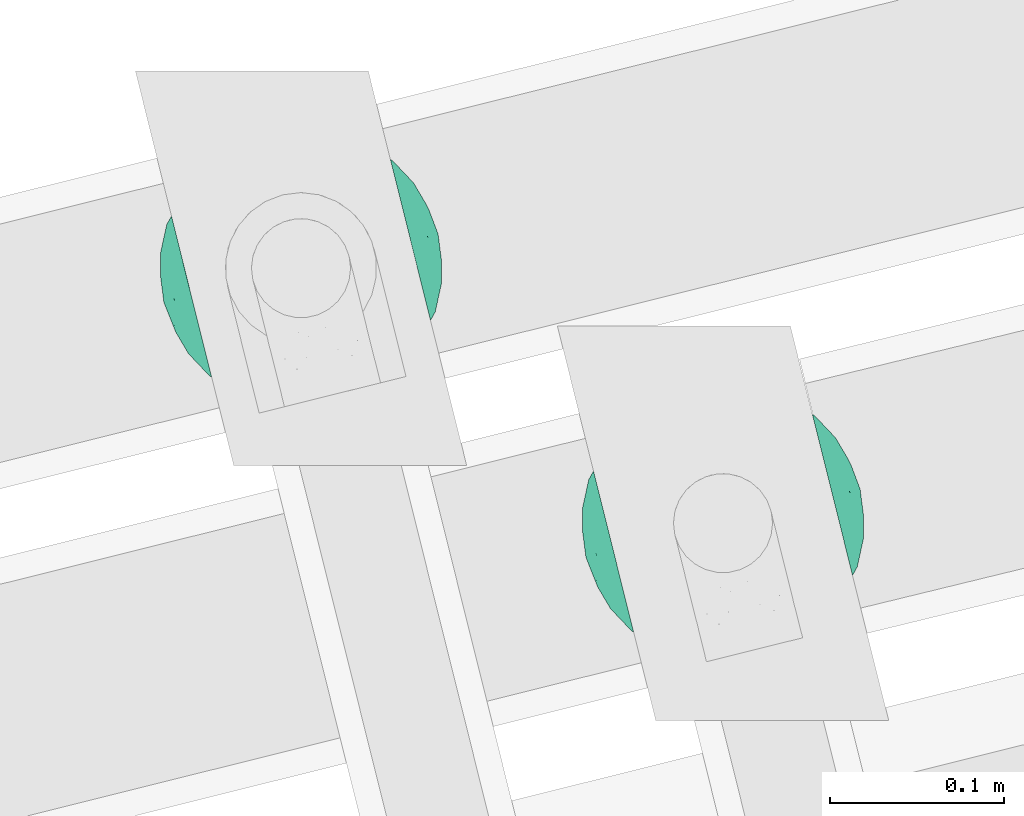
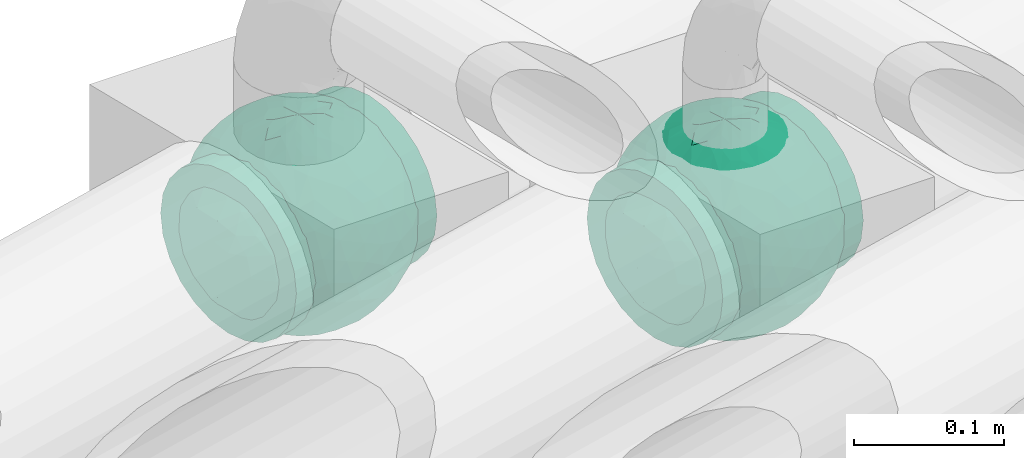
# One storey, part 56 of 93: 2 flow fittings.
"""IFC2X3 building model written with IfcOpenShell, lengths in millimetres."""

from ifc_helpers import new_model, entity, si_unit, converted_unit, derived_unit, direction, frame, origin, place, context, subcontext, project, spatial, faceted_brep, source, transform, mapped, material, material_list, type_object, type_shapes, element, save


model = new_model("IFC2X3")

# Units and contexts
model_context = context("Model", 3, precision=0.01, world=origin(), true_north=direction((6.12303176911189e-17, 1.0)))
body_context = subcontext(model_context, "Body", "Model", "MODEL_VIEW")
ifc_project = project(units=[si_unit("LENGTHUNIT", "METRE", prefix="MILLI"), si_unit("AREAUNIT", "SQUARE_METRE"), si_unit("VOLUMEUNIT", "CUBIC_METRE"), converted_unit("PLANEANGLEUNIT", "DEGREE", entity("IfcRatioMeasure", 0.0174532925199433), si_unit("PLANEANGLEUNIT", "RADIAN"), dimensions=[0, 0, 0, 0, 0, 0, 0]), si_unit("MASSUNIT", "GRAM", prefix="KILO"), derived_unit("MASSDENSITYUNIT", [(si_unit("MASSUNIT", "GRAM", prefix="KILO"), 1), (si_unit("LENGTHUNIT", "METRE"), -3)]), derived_unit("MOMENTOFINERTIAUNIT", [(si_unit("LENGTHUNIT", "METRE"), 4)]), si_unit("TIMEUNIT", "SECOND"), si_unit("FREQUENCYUNIT", "HERTZ"), si_unit("THERMODYNAMICTEMPERATUREUNIT", "DEGREE_CELSIUS"), derived_unit("THERMALTRANSMITTANCEUNIT", [(si_unit("MASSUNIT", "GRAM", prefix="KILO"), 1), (si_unit("THERMODYNAMICTEMPERATUREUNIT", "KELVIN"), -1), (si_unit("TIMEUNIT", "SECOND"), -3)]), derived_unit("VOLUMETRICFLOWRATEUNIT", [(si_unit("LENGTHUNIT", "METRE"), 3), (si_unit("TIMEUNIT", "SECOND"), -1)]), derived_unit("MASSFLOWRATEUNIT", [(si_unit("MASSUNIT", "GRAM", prefix="KILO"), 1), (si_unit("TIMEUNIT", "SECOND"), -1)]), derived_unit("ROTATIONALFREQUENCYUNIT", [(si_unit("TIMEUNIT", "SECOND"), -1)]), si_unit("ELECTRICCURRENTUNIT", "AMPERE"), si_unit("ELECTRICVOLTAGEUNIT", "VOLT"), si_unit("POWERUNIT", "WATT"), si_unit("FORCEUNIT", "NEWTON", prefix="KILO"), si_unit("ILLUMINANCEUNIT", "LUX"), si_unit("LUMINOUSFLUXUNIT", "LUMEN"), si_unit("LUMINOUSINTENSITYUNIT", "CANDELA"), derived_unit("USERDEFINED", [(si_unit("MASSUNIT", "GRAM", prefix="KILO"), -1), (si_unit("LENGTHUNIT", "METRE"), -2), (si_unit("TIMEUNIT", "SECOND"), 3), (si_unit("LUMINOUSFLUXUNIT", "LUMEN"), 1)]), derived_unit("LINEARVELOCITYUNIT", [(si_unit("LENGTHUNIT", "METRE"), 1), (si_unit("TIMEUNIT", "SECOND"), -1)]), si_unit("PRESSUREUNIT", "PASCAL"), derived_unit("USERDEFINED", [(si_unit("LENGTHUNIT", "METRE"), -2), (si_unit("MASSUNIT", "GRAM", prefix="KILO"), 1), (si_unit("TIMEUNIT", "SECOND"), -2)]), derived_unit("LINEARFORCEUNIT", [(si_unit("MASSUNIT", "GRAM", prefix="KILO"), 1), (si_unit("LENGTHUNIT", "METRE"), 1), (si_unit("TIMEUNIT", "SECOND"), -2), (si_unit("LENGTHUNIT", "METRE"), -1)]), derived_unit("PLANARFORCEUNIT", [(si_unit("MASSUNIT", "GRAM", prefix="KILO"), 1), (si_unit("LENGTHUNIT", "METRE"), 1), (si_unit("TIMEUNIT", "SECOND"), -2), (si_unit("LENGTHUNIT", "METRE"), -2)])], contexts=[model_context])

# Site, building, storey
site_placement = place(None, origin())
site = spatial("IfcSite", under=ifc_project, at=site_placement, CompositionType="ELEMENT")
building_placement = place(site_placement, origin())
building = spatial("IfcBuilding", under=site, at=building_placement, CompositionType="ELEMENT")
storey_placement = place(building_placement, frame((0.0, 0.0, -4200.0)))
storey = spatial("IfcBuildingStorey", under=building, at=storey_placement, CompositionType="ELEMENT", Elevation=-4200.0)

# Flow fittings
ifc_material_1 = material()
ifc_material_2 = material(Name="ADSK_")
ifc_material_list = material_list([ifc_material_1, ifc_material_2])
pipe_fitting_type = type_object("IfcPipeFittingType", Name="ADSK_2", PredefinedType="NOTDEFINED", material=ifc_material_list)
shared_shape = source(origin(), body_context, "Body", "Brep", [
    faceted_brep([(-65.0, 32.5, -56.29), (-65.0, 16.82, -62.79), (-65.0, 0.0, -65.0), (-65.0, -16.82, -62.79), (-65.0, -32.5, -56.29), (-65.0, -45.96, -45.96), (-65.0, -56.29, -32.5), (-65.0, -62.79, -16.82), (-65.0, -63.89, -8.41), (-65.0, -65.0, 0.0), (-65.0, -63.89, 8.41), (-65.0, -62.79, 16.82), (-65.0, -56.29, 32.5), (-65.0, -45.96, 45.96), (-65.0, -32.5, 56.29), (-65.0, -16.82, 62.79), (-65.0, 0.0, 65.0), (-65.0, 16.82, 62.79), (-65.0, 32.5, 56.29), (-65.0, 45.96, 45.96), (-65.0, 56.29, 32.5), (-65.0, 62.79, 16.82), (-65.0, 65.0, 0.0), (-65.0, 62.79, -16.82), (-65.0, 56.29, -32.5), (-65.0, 45.96, -45.96), (65.0, 0.0, -65.0), (65.0, 16.82, -62.79), (65.0, 32.5, -56.29), (65.0, 45.96, -45.96), (65.0, 56.29, -32.5), (65.0, 62.79, -16.82), (65.0, 65.0, 0.0), (65.0, 62.79, 16.82), (65.0, 56.29, 32.5), (65.0, 45.96, 45.96), (65.0, 32.5, 56.29), (65.0, 16.82, 62.79), (65.0, 0.0, 65.0), (65.0, -16.82, 62.79), (65.0, -32.5, 56.29), (65.0, -45.96, 45.96), (65.0, -56.29, 32.5), (65.0, -62.79, 16.82), (65.0, -63.89, 8.41), (65.0, -65.0, 0.0), (65.0, -63.89, -8.41), (65.0, -62.79, -16.82), (65.0, -56.29, -32.5), (65.0, -45.96, -45.96), (65.0, -32.5, -56.29), (65.0, -16.82, -62.79), (25.81, -64.3, 9.49), (27.5, -65.0, 0.0), (-27.5, -65.0, 0.0), (21.04, -62.54, 17.71), (4.82, -59.09, 27.07), (13.81, -60.49, 23.78), (9.32, -59.79, 25.43), (-25.81, -64.3, 9.48), (-26.66, -64.65, 4.74), (-21.05, -62.54, 17.7), (-13.81, -60.49, 23.78), (-9.32, -59.79, 25.43), (-4.83, -59.09, 27.07), (0.0, -59.09, 27.07), (26.66, -64.65, 4.74), (-25.81, -64.3, -9.48), (-26.66, -64.65, -4.74), (13.81, -60.49, -23.78), (9.32, -59.79, -25.43), (4.82, -59.09, -27.07), (25.81, -64.3, -9.49), (21.04, -62.54, -17.71), (26.66, -64.65, -4.74), (-4.83, -59.09, -27.07), (-9.32, -59.79, -25.43), (-13.81, -60.49, -23.78), (0.0, -59.09, -27.07), (-21.05, -62.54, -17.7), (0.0, -70.0, -27.5), (7.12, -70.0, -26.56), (13.75, -70.0, -23.82), (19.45, -70.0, -19.45), (23.82, -70.0, -13.75), (26.56, -70.0, -7.12), (27.5, -70.0, 0.0), (26.56, -70.0, 7.12), (23.82, -70.0, 13.75), (19.45, -70.0, 19.45), (13.75, -70.0, 23.82), (7.12, -70.0, 26.56), (0.0, -70.0, 27.5), (-7.12, -70.0, 26.56), (-13.75, -70.0, 23.82), (-19.45, -70.0, 19.45), (-23.82, -70.0, 13.75), (-26.56, -70.0, 7.12), (-27.5, -70.0, 0.0), (-26.56, -70.0, -7.12), (-23.82, -70.0, -13.75), (-19.45, -70.0, -19.45), (-13.75, -70.0, -23.82), (-7.12, -70.0, -26.56)], [[[0, 1, 2, 3, 4, 5, 6, 7, 8, 9, 10, 11, 12, 13, 14, 15, 16, 17, 18, 19, 20, 21, 22, 23, 24, 25]], [[26, 27, 28, 29, 30, 31, 32, 33, 34, 35, 36, 37, 38, 39, 40, 41, 42, 43, 44, 45, 46, 47, 48, 49, 50, 51]], [[44, 43, 52]], [[53, 45, 44]], [[9, 54, 10]], [[43, 55, 52]], [[56, 42, 12]], [[55, 43, 57]], [[42, 56, 58, 57]], [[42, 41, 13, 12]], [[57, 43, 42]], [[59, 11, 10]], [[10, 54, 60, 59]], [[59, 61, 11]], [[12, 62, 63, 64]], [[12, 11, 62]], [[12, 64, 65, 56]], [[62, 11, 61]], [[44, 52, 66, 53]], [[41, 40, 14, 13]], [[16, 15, 39, 38]], [[15, 14, 40, 39]], [[17, 16, 38, 37]], [[34, 33, 21, 20]], [[19, 18, 36, 35]], [[20, 19, 35, 34]], [[37, 36, 18, 17]], [[22, 21, 33, 32]], [[22, 32, 31, 23]], [[24, 30, 29, 25]], [[23, 31, 30, 24]], [[26, 51, 3, 2]], [[1, 0, 28, 27]], [[2, 1, 27, 26]], [[28, 0, 25, 29]], [[50, 4, 3, 51]], [[50, 49, 5, 4]], [[6, 5, 49, 48]], [[8, 67, 68, 54]], [[48, 69, 70, 71]], [[48, 47, 69]], [[6, 48, 71]], [[45, 53, 46]], [[8, 54, 9]], [[72, 73, 47]], [[46, 53, 74, 72]], [[47, 73, 69]], [[6, 75, 76, 77]], [[72, 47, 46]], [[77, 7, 6]], [[6, 71, 78, 75]], [[79, 67, 7]], [[67, 8, 7]], [[79, 7, 77]], [[80, 81, 82, 83, 84, 85, 86, 87, 88, 89, 90, 91, 92, 93, 94, 95, 96, 97, 98, 99, 100, 101, 102, 103]], [[97, 60, 98]], [[61, 96, 95]], [[97, 96, 59]], [[95, 94, 62]], [[97, 59, 60]], [[60, 54, 98]], [[59, 96, 61]], [[66, 52, 87]], [[93, 64, 63]], [[62, 61, 95]], [[92, 56, 65, 64]], [[90, 58, 91]], [[92, 64, 93]], [[56, 92, 91]], [[58, 90, 57]], [[55, 89, 88]], [[90, 89, 57]], [[52, 88, 87]], [[89, 55, 57]], [[56, 91, 58]], [[63, 62, 94]], [[86, 66, 87]], [[52, 55, 88]], [[66, 86, 53]], [[63, 94, 93]], [[85, 74, 86]], [[73, 84, 83]], [[85, 84, 72]], [[83, 82, 69]], [[85, 72, 74]], [[74, 53, 86]], [[72, 84, 73]], [[68, 67, 99]], [[81, 71, 70]], [[69, 73, 83]], [[80, 75, 78, 71]], [[102, 76, 103]], [[80, 71, 81]], [[75, 80, 103]], [[76, 102, 77]], [[79, 101, 100]], [[102, 101, 77]], [[67, 100, 99]], [[101, 79, 77]], [[75, 103, 76]], [[70, 69, 82]], [[98, 68, 99]], [[67, 79, 100]], [[68, 98, 54]], [[70, 82, 81]]]),
    faceted_brep([(-26.57, 76.36, -8.07), (-32.83, 71.49, -20.33), (-47.03, 64.85, -13.55), (22.24, -77.88, -6.48), (0.0, -81.25, 0.0), (14.57, -79.42, -9.02), (-19.55, 43.65, -65.68), (-6.7, 41.88, -69.3), (-15.5, 23.94, -76.08), (15.55, -78.16, 0.0), (20.63, -67.73, -39.86), (17.31, -55.39, -56.87), (33.39, -55.07, -49.54), (6.89, -77.99, -21.73), (13.76, -77.98, -18.22), (0.0, -79.9, -14.73), (-69.67, 30.72, -28.35), (-63.35, 45.14, -23.48), (-60.56, 38.81, -37.79), (-44.27, 66.26, 0.0), (8.9, -68.68, -42.49), (0.0, -57.53, -57.37), (-48.93, 45.14, -46.58), (-49.03, 57.11, -30.6), (-35.46, 62.54, -37.85), (76.18, -1.07, -28.23), (78.6, -12.72, -16.17), (71.53, -15.85, -35.12), (10.46, 67.82, -43.51), (0.0, 75.3, -30.53), (6.86, 78.01, -21.66), (-10.53, -67.73, -43.64), (0.0, -75.25, -30.63), (-6.89, -77.99, -21.73), (0.0, 81.25, 0.0), (15.55, 78.16, 0.0), (22.61, 77.77, -6.46), (-12.72, -56.34, -57.14), (-5.46, -45.53, -67.07), (44.37, 62.32, -27.38), (43.44, 67.56, -12.26), (56.18, 55.82, -18.18), (-13.79, 77.96, -18.26), (-25.89, 72.59, -25.72), (-16.58, 78.16, -14.76), (75.07, 31.09, 0.0), (74.86, 27.47, -15.59), (67.53, 42.93, -14.07), (13.79, 77.96, -18.26), (12.84, 79.64, -9.7), (21.38, 75.85, -19.79), (74.72, 15.85, -27.69), (79.59, 7.96, -14.27), (43.73, -67.56, -11.18), (57.45, -57.45, 0.0), (44.27, -66.26, 0.0), (63.35, -45.14, -23.48), (61.82, -51.54, -11.09), (49.12, -59.87, -24.59), (78.16, 15.55, 0.0), (50.83, -12.03, -62.24), (35.62, -9.55, -72.4), (43.7, 11.32, -67.56), (72.48, -29.04, -22.46), (-44.38, -62.32, -27.37), (-26.83, -74.87, -16.61), (-43.44, -67.56, -12.26), (-13.76, -77.98, -18.22), (-12.85, -79.64, -9.7), (-21.39, -75.84, -19.81), (-2.49, -31.04, -75.05), (8.59, -44.22, -67.62), (-74.72, -15.85, -27.69), (-68.67, -30.94, -30.47), (-74.55, -27.6, -16.8), (-75.07, 31.09, 0.0), (-71.41, 36.12, -14.04), (-75.88, 22.59, -18.27), (-22.61, -77.77, -6.46), (-16.87, -79.04, -8.34), (28.21, -26.53, -71.43), (13.03, -29.67, -74.51), (18.2, -9.78, -78.58), (-56.42, -55.66, -17.92), (6.0, 45.8, -66.84), (0.0, 57.69, -57.22), (-78.16, -15.55, 0.0), (-79.59, -7.96, -14.27), (32.83, -71.49, -20.33), (-15.55, -78.16, 0.0), (-20.62, 67.82, -39.72), (-33.11, 50.34, -54.51), (-61.82, 51.54, -11.09), (-66.26, 44.27, 0.0), (75.07, -31.09, 0.0), (66.26, -44.27, 0.0), (-6.86, 78.01, -21.66), (0.0, 79.92, -14.67), (26.82, 74.88, -16.61), (16.85, 79.04, -8.33), (-8.98, 69.99, -40.29), (38.78, -61.98, -35.46), (48.93, -45.14, -46.58), (55.26, -48.62, -34.41), (-71.53, 15.85, -35.12), (-78.76, 7.96, -18.29), (-17.06, 58.9, -53.31), (-15.55, 78.16, 0.0), (13.32, 55.85, -57.49), (21.86, 61.99, -47.75), (-15.13, 79.31, -9.05), (26.19, -72.28, -26.28), (17.27, -77.87, -15.49), (-29.57, -28.73, -70.02), (-26.25, -43.22, -63.6), (-42.18, -36.82, -58.88), (41.25, 41.74, -56.2), (54.79, 33.3, -49.91), (40.91, 28.53, -64.14), (38.98, -38.31, -60.12), (52.67, -28.88, -54.71), (68.84, 3.22, -43.04), (66.02, 21.29, -42.31), (-42.82, 33.53, -60.37), (-55.21, 10.46, -58.69), (-57.08, 27.98, -50.61), (-56.33, -15.85, -56.37), (-55.8, -33.3, -48.77), (-66.18, -20.5, -42.45), (31.09, 75.07, 0.0), (44.27, 66.26, 0.0), (57.45, 57.45, 0.0), (-31.09, -75.07, 0.0), (-57.45, -57.45, 0.0), (1.56, 67.82, -44.72), (-1.57, -67.73, -44.86), (22.55, 72.77, -28.25), (16.53, 72.17, -33.48), (-22.52, -72.77, -28.27), (-16.58, -72.47, -32.79), (28.96, -66.23, -37.11), (62.57, -34.08, -39.05), (62.37, -15.41, -49.74), (68.82, 31.09, -29.97), (-66.06, -1.38, -47.28), (-67.87, -42.27, -14.43), (29.1, 65.34, -38.54), (33.22, 68.08, -29.37), (46.02, 49.13, -45.5), (10.35, 15.34, -79.12), (0.0, 0.22, -81.25), (-29.12, -65.31, -38.57), (-22.07, -61.55, -48.23), (-33.19, -68.12, -29.33), (-46.02, -49.17, -45.45), (-34.11, 19.17, -71.21), (-23.02, 4.97, -77.76), (-40.38, 0.85, -70.5), (2.47, 31.35, -74.92), (16.3, 35.47, -71.26), (-13.73, -8.11, -79.67), (-28.12, -13.42, -75.04), (33.83, 54.01, -50.4), (26.1, 43.46, -63.49), (24.94, -42.3, -64.73), (-16.13, -35.64, -71.21), (0.28, -15.85, -79.69), (-13.57, -22.47, -76.89), (60.35, 45.14, -30.37), (-60.34, -45.14, -30.38), (-33.99, -54.1, -50.2), (-57.45, 57.45, 0.0), (-42.67, -18.04, -66.75), (-63.99, 15.14, -47.72), (-81.25, 0.0, 0.0), (-78.16, 15.55, 0.0), (-74.66, 0.0, -32.06), (-31.09, 75.07, 0.0), (31.09, -75.07, 0.0), (56.37, 15.85, -56.33), (28.0, 13.82, -75.01), (66.26, 44.27, 0.0), (81.25, 0.0, 0.0), (78.16, -15.55, 0.0), (-66.26, -44.27, 0.0), (-75.07, -31.09, 0.0), (-44.27, -66.26, 0.0), (26.57, 76.36, 8.07), (32.83, 71.49, 20.33), (47.03, 64.85, 13.55), (-22.24, -77.88, 6.48), (-14.57, -79.42, 9.02), (19.55, 43.65, 65.68), (6.7, 41.88, 69.3), (15.5, 23.94, 76.08), (-20.63, -67.73, 39.86), (-17.31, -55.39, 56.87), (-33.39, -55.07, 49.54), (-6.89, -77.99, 21.73), (-13.76, -77.98, 18.22), (0.0, -79.9, 14.73), (69.67, 30.72, 28.35), (63.35, 45.14, 23.48), (60.56, 38.81, 37.79), (-8.9, -68.68, 42.49), (0.0, -57.53, 57.37), (48.93, 45.14, 46.58), (49.03, 57.11, 30.6), (35.46, 62.54, 37.85), (-76.18, -1.07, 28.23), (-78.6, -12.72, 16.17), (-71.53, -15.85, 35.12), (-10.46, 67.82, 43.51), (0.0, 75.3, 30.53), (-6.86, 78.01, 21.66), (10.53, -67.73, 43.64), (0.0, -75.25, 30.63), (6.89, -77.99, 21.73), (-22.61, 77.77, 6.46), (12.72, -56.34, 57.14), (5.46, -45.53, 67.07), (-44.37, 62.32, 27.38), (-43.44, 67.56, 12.26), (-56.18, 55.82, 18.18), (13.79, 77.96, 18.26), (25.89, 72.59, 25.72), (16.58, 78.16, 14.76), (-74.86, 27.47, 15.59), (-67.53, 42.93, 14.07), (-13.79, 77.96, 18.26), (-12.84, 79.64, 9.7), (-21.38, 75.85, 19.79), (-74.72, 15.85, 27.69), (-79.59, 7.96, 14.27), (-43.73, -67.56, 11.18), (-63.35, -45.14, 23.48), (-61.82, -51.54, 11.09), (-49.12, -59.87, 24.59), (-50.83, -12.03, 62.24), (-35.62, -9.55, 72.4), (-43.7, 11.32, 67.56), (-72.48, -29.04, 22.46), (44.38, -62.32, 27.37), (26.83, -74.87, 16.61), (43.44, -67.56, 12.26), (13.76, -77.98, 18.22), (12.85, -79.64, 9.7), (21.39, -75.84, 19.81), (2.49, -31.04, 75.05), (-8.59, -44.22, 67.62), (74.72, -15.85, 27.69), (68.67, -30.94, 30.47), (74.55, -27.6, 16.8), (71.41, 36.12, 14.04), (75.88, 22.59, 18.27), (22.61, -77.77, 6.46), (16.87, -79.04, 8.34), (-28.21, -26.53, 71.43), (-13.03, -29.67, 74.51), (-18.2, -9.78, 78.58), (56.42, -55.66, 17.92), (-6.0, 45.8, 66.84), (0.0, 57.69, 57.22), (78.78, -14.01, 14.13), (-32.83, -71.49, 20.33), (20.62, 67.82, 39.72), (33.11, 50.34, 54.51), (61.82, 51.54, 11.09), (6.86, 78.01, 21.66), (0.0, 79.92, 14.67), (-26.82, 74.88, 16.61), (-16.85, 79.04, 8.33), (8.98, 69.99, 40.29), (-38.78, -61.98, 35.46), (-48.93, -45.14, 46.58), (-55.26, -48.62, 34.41), (71.53, 15.85, 35.12), (78.76, 7.96, 18.29), (17.06, 58.9, 53.31), (-13.32, 55.85, 57.49), (-21.86, 61.99, 47.75), (15.13, 79.31, 9.05), (-26.19, -72.28, 26.28), (-17.27, -77.87, 15.49), (29.57, -28.73, 70.02), (26.25, -43.22, 63.6), (42.18, -36.82, 58.88), (-41.25, 41.74, 56.2), (-54.79, 33.3, 49.91), (-40.91, 28.53, 64.14), (-38.98, -38.31, 60.12), (-52.67, -28.88, 54.71), (-68.84, 3.22, 43.04), (-66.02, 21.29, 42.31), (42.82, 33.53, 60.37), (55.21, 10.46, 58.69), (57.08, 27.98, 50.61), (56.33, -15.85, 56.37), (55.8, -33.3, 48.77), (66.18, -20.5, 42.45), (-1.56, 67.82, 44.72), (1.57, -67.73, 44.86), (-22.55, 72.77, 28.25), (-16.53, 72.17, 33.48), (22.52, -72.77, 28.27), (16.58, -72.47, 32.79), (-28.96, -66.23, 37.11), (-62.57, -34.08, 39.05), (-62.37, -15.41, 49.74), (-68.82, 31.09, 29.97), (66.06, -1.38, 47.28), (67.87, -42.27, 14.43), (-29.1, 65.34, 38.54), (-33.22, 68.08, 29.37), (-46.02, 49.13, 45.5), (-10.35, 15.34, 79.12), (0.0, 0.22, 81.25), (29.12, -65.31, 38.57), (22.07, -61.55, 48.23), (33.19, -68.12, 29.33), (46.02, -49.17, 45.45), (34.11, 19.17, 71.21), (23.02, 4.97, 77.76), (40.38, 0.85, 70.5), (-2.47, 31.35, 74.92), (-16.3, 35.47, 71.26), (13.73, -8.11, 79.67), (28.12, -13.42, 75.04), (-33.83, 54.01, 50.4), (-26.1, 43.46, 63.49), (-24.94, -42.3, 64.73), (16.13, -35.64, 71.21), (-0.28, -15.85, 79.69), (13.57, -22.47, 76.89), (-60.35, 45.14, 30.37), (60.34, -45.14, 30.38), (33.99, -54.1, 50.2), (42.67, -18.04, 66.75), (63.99, 15.14, 47.72), (74.66, 0.0, 32.06), (-56.37, 15.85, 56.33), (-28.0, 13.82, 75.01)], [[[0, 1, 2]], [[3, 4, 5]], [[6, 7, 8]], [[4, 3, 9]], [[10, 11, 12]], [[13, 14, 4]], [[13, 4, 15]], [[16, 17, 18]], [[19, 0, 2]], [[20, 21, 11]], [[22, 23, 24]], [[25, 26, 27]], [[28, 29, 30]], [[31, 32, 33]], [[34, 35, 36]], [[37, 38, 21]], [[39, 40, 41]], [[42, 43, 44]], [[45, 46, 47]], [[30, 34, 48]], [[49, 50, 48]], [[51, 46, 52]], [[53, 54, 55]], [[56, 57, 58]], [[46, 59, 52]], [[60, 61, 62]], [[27, 26, 63]], [[64, 65, 66]], [[67, 68, 69]], [[38, 70, 71]], [[72, 73, 74]], [[15, 33, 32]], [[75, 76, 77]], [[78, 65, 79]], [[80, 81, 82]], [[64, 66, 83]], [[84, 7, 85]], [[74, 86, 87]], [[88, 53, 3]], [[4, 89, 78]], [[24, 90, 91]], [[92, 76, 93]], [[94, 95, 63]], [[96, 34, 97]], [[36, 98, 99]], [[96, 42, 34]], [[96, 100, 90]], [[101, 102, 103]], [[77, 104, 105]], [[90, 106, 91]], [[34, 0, 107]], [[84, 85, 108]], [[109, 108, 28]], [[0, 110, 1]], [[14, 111, 112]], [[97, 30, 29]], [[39, 98, 40]], [[67, 33, 4]], [[113, 114, 115]], [[116, 117, 118]], [[119, 60, 120]], [[121, 122, 51]], [[123, 124, 125]], [[126, 127, 128]], [[129, 40, 36]], [[130, 131, 40]], [[132, 66, 78]], [[133, 83, 66]], [[97, 29, 96]], [[28, 108, 134]], [[100, 96, 29]], [[44, 34, 42]], [[15, 32, 13]], [[32, 31, 135]], [[20, 13, 32]], [[112, 4, 14]], [[48, 136, 137]], [[96, 90, 42]], [[90, 24, 43]], [[68, 67, 4]], [[67, 138, 139]], [[13, 10, 14]], [[140, 101, 111]], [[53, 58, 57]], [[141, 102, 120]], [[27, 142, 121]], [[46, 51, 143]], [[23, 2, 1]], [[125, 18, 22]], [[124, 126, 144]], [[73, 145, 74]], [[30, 137, 28]], [[28, 137, 109]], [[146, 147, 148]], [[149, 150, 8]], [[151, 152, 139]], [[152, 114, 37]], [[151, 153, 154]], [[155, 156, 157]], [[158, 84, 159]], [[156, 8, 150]], [[156, 160, 161]], [[155, 124, 123]], [[162, 116, 163]], [[119, 80, 60]], [[12, 102, 101]], [[81, 164, 71]], [[91, 123, 22]], [[100, 106, 90]], [[70, 38, 165]], [[81, 70, 166]], [[167, 113, 161]], [[156, 161, 157]], [[131, 47, 41]], [[36, 40, 98]], [[148, 39, 168]], [[146, 136, 147]], [[143, 117, 168]], [[146, 162, 109]], [[99, 34, 36]], [[133, 145, 83]], [[78, 66, 65]], [[154, 64, 169]], [[151, 138, 153]], [[115, 127, 126]], [[151, 170, 152]], [[79, 4, 78]], [[134, 100, 29]], [[85, 7, 106]], [[85, 106, 100]], [[91, 106, 6]], [[123, 6, 155]], [[91, 22, 24]], [[22, 18, 23]], [[43, 24, 1]], [[92, 17, 76]], [[1, 24, 23]], [[17, 2, 23]], [[92, 171, 2]], [[110, 0, 34]], [[6, 123, 91]], [[157, 161, 172]], [[144, 126, 128]], [[123, 125, 22]], [[124, 173, 125]], [[104, 16, 18]], [[18, 125, 173]], [[23, 18, 17]], [[105, 174, 175]], [[76, 17, 16]], [[105, 176, 87]], [[77, 175, 75]], [[176, 105, 104]], [[77, 76, 16]], [[76, 75, 93]], [[93, 171, 92]], [[177, 0, 19]], [[2, 17, 92]], [[104, 77, 16]], [[175, 77, 105]], [[3, 53, 178]], [[53, 88, 58]], [[88, 3, 5]], [[101, 58, 88]], [[56, 103, 141]], [[111, 101, 88]], [[101, 140, 12]], [[10, 20, 11]], [[119, 102, 12]], [[71, 70, 81]], [[119, 164, 80]], [[164, 12, 11]], [[80, 82, 61]], [[51, 25, 121]], [[119, 120, 102]], [[13, 20, 10]], [[20, 32, 135]], [[60, 142, 120]], [[56, 58, 103]], [[142, 141, 120]], [[63, 141, 27]], [[121, 60, 179]], [[141, 142, 27]], [[60, 121, 142]], [[122, 121, 179]], [[117, 122, 179]], [[143, 51, 122]], [[117, 179, 118]], [[168, 117, 148]], [[62, 118, 179]], [[159, 118, 180]], [[117, 143, 122]], [[143, 168, 47]], [[41, 47, 168]], [[47, 131, 181]], [[47, 46, 143]], [[46, 45, 59]], [[59, 182, 52]], [[26, 52, 182]], [[25, 51, 52]], [[26, 182, 183]], [[95, 57, 63]], [[26, 25, 52]], [[121, 25, 27]], [[94, 63, 26]], [[141, 63, 56]], [[53, 57, 54]], [[54, 57, 95]], [[63, 57, 56]], [[39, 41, 168]], [[41, 40, 131]], [[12, 164, 119]], [[164, 11, 71]], [[11, 21, 71]], [[38, 71, 21]], [[21, 135, 37]], [[38, 37, 165]], [[152, 37, 31]], [[165, 37, 114]], [[139, 31, 33]], [[151, 154, 170]], [[31, 139, 152]], [[67, 139, 33]], [[113, 165, 114]], [[167, 161, 160]], [[114, 170, 115]], [[172, 161, 113]], [[127, 115, 154]], [[172, 115, 126]], [[115, 172, 113]], [[157, 126, 124]], [[126, 157, 172]], [[124, 155, 157]], [[8, 156, 155]], [[160, 156, 150]], [[6, 8, 155]], [[8, 158, 149]], [[154, 169, 127]], [[128, 73, 72]], [[73, 127, 169]], [[176, 144, 128]], [[176, 128, 72]], [[173, 144, 104]], [[115, 170, 154]], [[114, 152, 170]], [[127, 73, 128]], [[73, 169, 145]], [[83, 145, 169]], [[145, 133, 184]], [[145, 185, 74]], [[74, 185, 86]], [[87, 86, 174]], [[105, 87, 174]], [[74, 87, 72]], [[64, 83, 169]], [[66, 132, 186]], [[167, 166, 70]], [[164, 81, 80]], [[149, 82, 150]], [[80, 61, 60]], [[82, 180, 61]], [[62, 180, 118]], [[112, 88, 5]], [[140, 14, 10]], [[166, 160, 150]], [[165, 167, 70]], [[150, 82, 166]], [[81, 166, 82]], [[167, 165, 113]], [[166, 167, 160]], [[88, 112, 111]], [[4, 112, 5]], [[144, 176, 104]], [[87, 176, 72]], [[101, 103, 58]], [[102, 141, 103]], [[60, 62, 179]], [[61, 180, 62]], [[14, 140, 111]], [[12, 140, 10]], [[48, 137, 30]], [[109, 137, 146]], [[162, 146, 148]], [[108, 85, 134]], [[109, 163, 108]], [[163, 159, 84]], [[116, 162, 148]], [[163, 109, 162]], [[163, 84, 108]], [[7, 84, 158]], [[118, 159, 163]], [[149, 159, 180]], [[8, 7, 158]], [[7, 6, 106]], [[117, 116, 148]], [[163, 116, 118]], [[98, 49, 99]], [[50, 49, 98]], [[34, 49, 48]], [[147, 98, 39]], [[136, 48, 50]], [[147, 39, 148]], [[137, 136, 146]], [[136, 50, 147]], [[98, 147, 50]], [[34, 99, 49]], [[65, 68, 79]], [[68, 65, 69]], [[153, 65, 64]], [[138, 67, 69]], [[153, 64, 154]], [[139, 138, 151]], [[138, 69, 153]], [[65, 153, 69]], [[4, 79, 68]], [[34, 30, 97]], [[4, 33, 15]], [[100, 134, 85]], [[29, 28, 134]], [[37, 135, 31]], [[20, 135, 21]], [[159, 149, 158]], [[82, 149, 180]], [[40, 129, 130]], [[186, 133, 66]], [[44, 1, 110]], [[90, 43, 42]], [[1, 44, 43]], [[34, 44, 110]], [[2, 171, 19]], [[0, 177, 107]], [[144, 173, 124]], [[18, 173, 104]], [[3, 178, 9]], [[55, 178, 53]], [[181, 45, 47]], [[94, 26, 183]], [[184, 185, 145]], [[35, 129, 36]], [[89, 132, 78]], [[187, 188, 189]], [[190, 4, 191]], [[192, 193, 194]], [[4, 190, 89]], [[195, 196, 197]], [[198, 199, 4]], [[198, 4, 200]], [[201, 202, 203]], [[130, 187, 189]], [[204, 205, 196]], [[206, 207, 208]], [[209, 210, 211]], [[212, 213, 214]], [[215, 216, 217]], [[34, 107, 218]], [[219, 220, 205]], [[221, 222, 223]], [[224, 225, 226]], [[75, 227, 228]], [[214, 34, 229]], [[230, 231, 229]], [[232, 227, 233]], [[234, 133, 186]], [[235, 236, 237]], [[227, 175, 233]], [[238, 239, 240]], [[211, 210, 241]], [[242, 243, 244]], [[245, 246, 247]], [[220, 248, 249]], [[250, 251, 252]], [[200, 217, 216]], [[45, 253, 254]], [[255, 243, 256]], [[257, 258, 259]], [[242, 244, 260]], [[261, 193, 262]], [[252, 183, 263]], [[264, 234, 190]], [[4, 9, 255]], [[208, 265, 266]], [[267, 253, 181]], [[185, 184, 241]], [[268, 34, 269]], [[218, 270, 271]], [[268, 224, 34]], [[268, 272, 265]], [[273, 274, 275]], [[254, 276, 277]], [[265, 278, 266]], [[34, 187, 35]], [[261, 262, 279]], [[280, 279, 212]], [[187, 281, 188]], [[199, 282, 283]], [[269, 214, 213]], [[221, 270, 222]], [[245, 217, 4]], [[284, 285, 286]], [[287, 288, 289]], [[290, 238, 291]], [[292, 293, 232]], [[294, 295, 296]], [[297, 298, 299]], [[177, 222, 218]], [[171, 223, 222]], [[178, 244, 255]], [[54, 260, 244]], [[269, 213, 268]], [[34, 230, 229]], [[212, 279, 300]], [[272, 268, 213]], [[226, 34, 224]], [[200, 216, 198]], [[216, 215, 301]], [[204, 198, 216]], [[229, 302, 303]], [[268, 265, 224]], [[265, 208, 225]], [[246, 245, 4]], [[245, 304, 305]], [[198, 195, 199]], [[306, 273, 282]], [[234, 237, 236]], [[307, 274, 291]], [[211, 308, 292]], [[227, 232, 309]], [[207, 189, 188]], [[296, 203, 206]], [[295, 297, 310]], [[251, 311, 252]], [[214, 303, 212]], [[212, 303, 280]], [[312, 313, 314]], [[315, 316, 194]], [[317, 318, 305]], [[318, 285, 219]], [[317, 319, 320]], [[321, 322, 323]], [[324, 261, 325]], [[322, 194, 316]], [[322, 326, 327]], [[321, 295, 294]], [[328, 287, 329]], [[290, 257, 238]], [[197, 274, 273]], [[258, 330, 249]], [[266, 294, 206]], [[272, 278, 265]], [[248, 220, 331]], [[258, 248, 332]], [[333, 284, 327]], [[322, 327, 323]], [[171, 228, 223]], [[218, 222, 270]], [[314, 221, 334]], [[312, 302, 313]], [[309, 288, 334]], [[312, 328, 280]], [[271, 34, 218]], [[54, 311, 260]], [[255, 244, 243]], [[320, 242, 335]], [[317, 304, 319]], [[286, 298, 297]], [[317, 336, 318]], [[256, 4, 255]], [[300, 272, 213]], [[262, 193, 278]], [[262, 278, 272]], [[266, 278, 192]], [[294, 192, 321]], [[266, 206, 208]], [[206, 203, 207]], [[225, 208, 188]], [[267, 202, 253]], [[188, 208, 207]], [[202, 189, 207]], [[267, 131, 189]], [[281, 187, 34]], [[192, 294, 266]], [[323, 327, 337]], [[310, 297, 299]], [[294, 296, 206]], [[295, 338, 296]], [[276, 201, 203]], [[203, 296, 338]], [[207, 203, 202]], [[277, 182, 59]], [[253, 202, 201]], [[263, 250, 252]], [[254, 59, 45]], [[339, 277, 276]], [[254, 253, 201]], [[253, 45, 181]], [[181, 131, 267]], [[129, 187, 130]], [[189, 202, 267]], [[276, 254, 201]], [[59, 254, 277]], [[190, 234, 132]], [[234, 264, 237]], [[272, 300, 262]], [[264, 190, 191]], [[273, 237, 264]], [[235, 275, 307]], [[282, 273, 264]], [[273, 306, 197]], [[195, 204, 196]], [[290, 274, 197]], [[249, 248, 258]], [[290, 330, 257]], [[330, 197, 196]], [[257, 259, 239]], [[232, 209, 292]], [[290, 291, 274]], [[198, 204, 195]], [[204, 216, 301]], [[238, 308, 291]], [[235, 237, 275]], [[308, 307, 291]], [[241, 307, 211]], [[292, 238, 340]], [[307, 308, 211]], [[238, 292, 308]], [[293, 292, 340]], [[288, 293, 340]], [[309, 232, 293]], [[288, 340, 289]], [[334, 288, 314]], [[240, 289, 340]], [[325, 289, 341]], [[288, 309, 293]], [[309, 334, 228]], [[223, 228, 334]], [[228, 171, 93]], [[228, 227, 309]], [[227, 75, 175]], [[175, 174, 233]], [[210, 233, 174]], [[209, 232, 233]], [[210, 174, 86]], [[184, 236, 241]], [[210, 209, 233]], [[292, 209, 211]], [[185, 241, 210]], [[307, 241, 235]], [[234, 236, 133]], [[133, 236, 184]], [[241, 236, 235]], [[221, 223, 334]], [[222, 177, 19]], [[197, 330, 290]], [[330, 196, 249]], [[196, 205, 249]], [[220, 249, 205]], [[205, 301, 219]], [[220, 219, 331]], [[318, 219, 215]], [[331, 219, 285]], [[305, 215, 217]], [[317, 320, 336]], [[215, 305, 318]], [[245, 305, 217]], [[284, 331, 285]], [[333, 327, 326]], [[285, 336, 286]], [[337, 327, 284]], [[298, 286, 320]], [[337, 286, 297]], [[286, 337, 284]], [[323, 297, 295]], [[297, 323, 337]], [[295, 321, 323]], [[194, 322, 321]], [[326, 322, 316]], [[192, 194, 321]], [[194, 324, 315]], [[320, 335, 298]], [[299, 251, 250]], [[251, 298, 335]], [[339, 310, 299]], [[339, 299, 250]], [[338, 310, 276]], [[286, 336, 320]], [[285, 318, 336]], [[298, 251, 299]], [[251, 335, 311]], [[260, 311, 335]], [[311, 54, 95]], [[311, 94, 252]], [[252, 94, 183]], [[182, 277, 263]], [[182, 263, 183]], [[339, 263, 277]], [[242, 260, 335]], [[244, 178, 55]], [[333, 332, 248]], [[330, 258, 257]], [[315, 259, 316]], [[257, 239, 238]], [[259, 341, 239]], [[240, 341, 289]], [[283, 264, 191]], [[306, 199, 195]], [[332, 326, 316]], [[331, 333, 248]], [[316, 259, 332]], [[258, 332, 259]], [[333, 331, 284]], [[332, 333, 326]], [[264, 283, 282]], [[4, 283, 191]], [[310, 339, 276]], [[263, 339, 250]], [[273, 275, 237]], [[274, 307, 275]], [[238, 240, 340]], [[239, 341, 240]], [[199, 306, 282]], [[197, 306, 195]], [[229, 303, 214]], [[280, 303, 312]], [[328, 312, 314]], [[279, 262, 300]], [[280, 329, 279]], [[329, 325, 261]], [[287, 328, 314]], [[329, 280, 328]], [[329, 261, 279]], [[193, 261, 324]], [[289, 325, 329]], [[315, 325, 341]], [[194, 193, 324]], [[193, 192, 278]], [[288, 287, 314]], [[329, 287, 289]], [[270, 230, 271]], [[231, 230, 270]], [[313, 270, 221]], [[302, 229, 231]], [[313, 221, 314]], [[303, 302, 312]], [[302, 231, 313]], [[270, 313, 231]], [[34, 271, 230]], [[243, 246, 256]], [[246, 243, 247]], [[319, 243, 242]], [[304, 245, 247]], [[319, 242, 320]], [[305, 304, 317]], [[304, 247, 319]], [[243, 319, 247]], [[4, 256, 246]], [[34, 214, 269]], [[4, 217, 200]], [[4, 199, 283]], [[213, 212, 300]], [[219, 301, 215]], [[204, 301, 205]], [[325, 315, 324]], [[259, 315, 341]], [[19, 171, 222]], [[55, 54, 244]], [[226, 188, 281]], [[265, 225, 224]], [[188, 226, 225]], [[34, 226, 281]], [[189, 131, 130]], [[187, 129, 35]], [[310, 338, 295]], [[203, 338, 276]], [[190, 132, 89]], [[186, 132, 234]], [[93, 75, 228]], [[185, 210, 86]], [[95, 94, 311]], [[107, 177, 218]], [[9, 178, 255]]]),
])
type_shapes(pipe_fitting_type, [shared_shape])
for number, where, z_axis, x_axis, name in (
    (1, (-8048.92, 13858.5, 2500.0), (0.241921895599631, -0.970295726276006, 0.0), (-0.970295726276006, -0.241921895599631, 0.0), "ADSK_2"),
    (2, (-7806.23, 13711.87, 2499.91), (0.241921895599629, -0.970295726276006, 0.0), (-0.970295726276006, -0.241921895599629, 0.0), "ADSK_2"),
):
    element("IfcFlowFitting", number, at=place(storey_placement, frame(where, z_axis=z_axis, x_axis=x_axis)), inside=storey, type_object=pipe_fitting_type, material=ifc_material_list, Name=name, ObjectType="ADSK_2", context=body_context, shape_type="MappedRepresentation", body=[
        mapped(shared_shape, transform((0.0, 0.0, 0.0), scale=1.0)),
    ])

save(model, "model.ifc")
